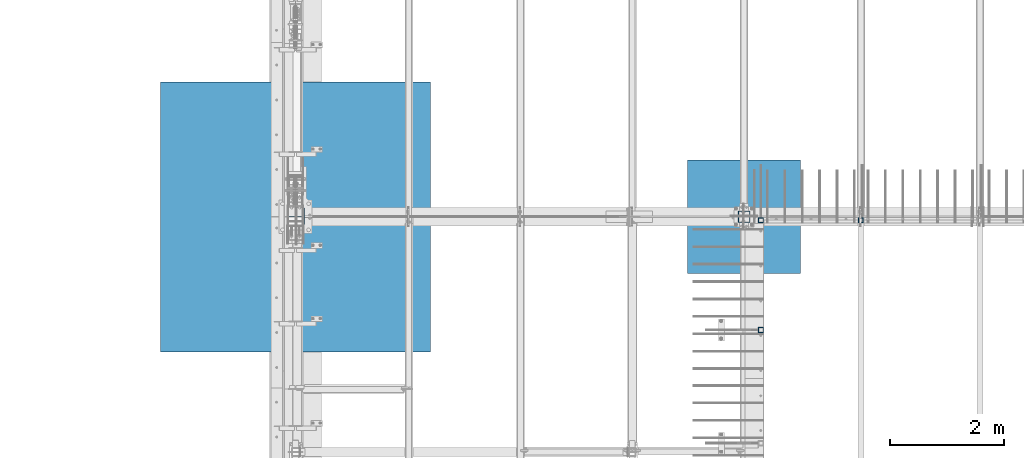
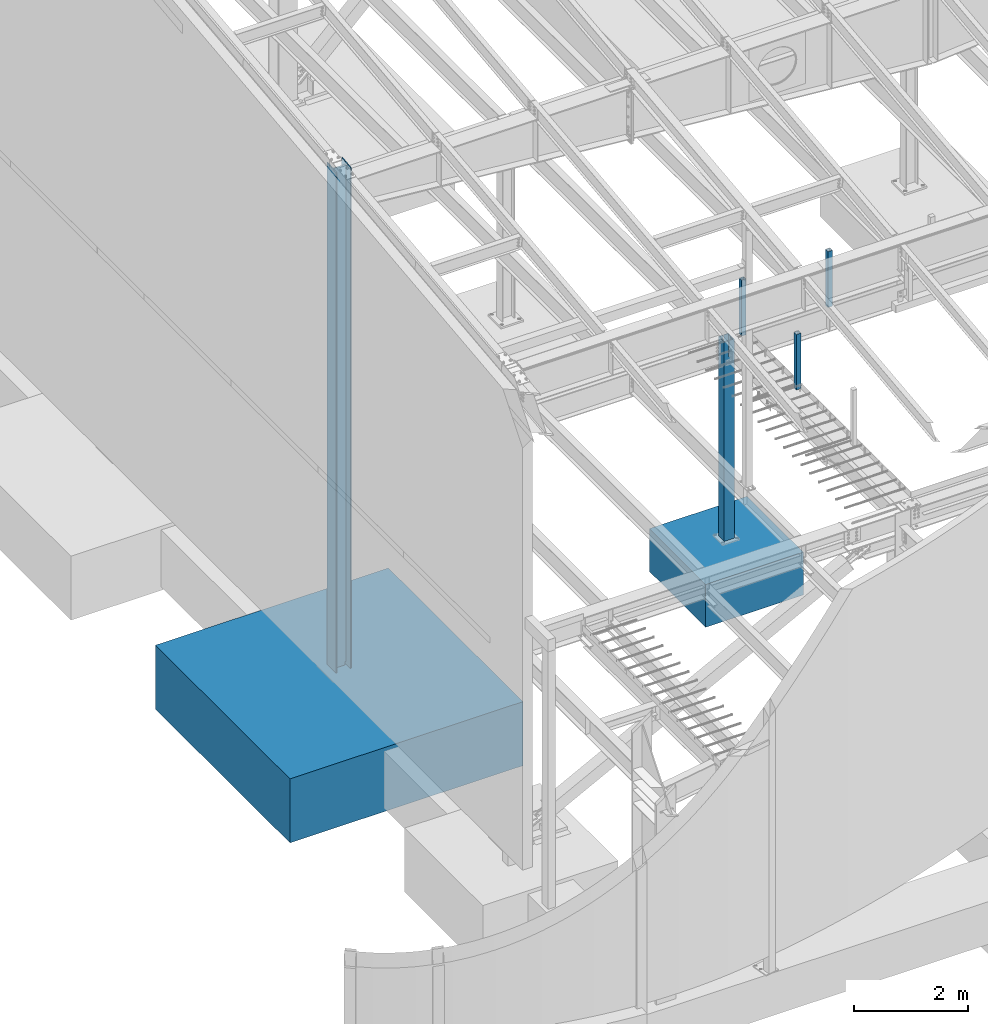
# One storey, part 352 of 1179: 7 columns, 7 elements without a shape of their own.
"""IFC2X3 building model written with IfcOpenShell, lengths in millimetres."""

from ifc_helpers import new_model, si_unit, frame, origin_with_axes, place, context, subcontext, project, spatial, faceted_brep, material, type_object, element, aggregate, save


model = new_model("IFC2X3")

# Units and contexts
model_context = context("Model", 3, precision=1e-05, world=origin_with_axes())
body_context = subcontext(model_context, "Body", "Model", "MODEL_VIEW")
ifc_project = project(units=[si_unit("LENGTHUNIT", "METRE", prefix="MILLI"), si_unit("AREAUNIT", "SQUARE_METRE"), si_unit("VOLUMEUNIT", "CUBIC_METRE"), si_unit("MASSUNIT", "GRAM", prefix="KILO"), si_unit("TIMEUNIT", "SECOND"), si_unit("PLANEANGLEUNIT", "RADIAN"), si_unit("SOLIDANGLEUNIT", "STERADIAN"), si_unit("THERMODYNAMICTEMPERATUREUNIT", "DEGREE_CELSIUS"), si_unit("LUMINOUSINTENSITYUNIT", "LUMEN")], contexts=[model_context])

# Site, building, storey
site_placement = place(None, origin_with_axes())
site = spatial("IfcSite", under=ifc_project, at=site_placement, CompositionType="ELEMENT")
building_placement = place(site_placement, origin_with_axes())
building = spatial("IfcBuilding", under=site, at=building_placement, Name="Undefined", CompositionType="ELEMENT")
storey_placement = place(building_placement, origin_with_axes())
storey = spatial("IfcBuildingStorey", under=building, at=storey_placement, Name="Undefined", CompositionType="ELEMENT", Elevation=0.0)

# Assembly, column
assembly_1_placement = place(storey_placement, origin_with_axes())
assembly_1 = element("IfcElementAssembly", 1, at=assembly_1_placement, inside=storey, Name="COLUMN", AssemblyPlace="NOTDEFINED", PredefinedType="RIGID_FRAME")
ifc_material_1 = material()
column_type_1 = type_object("IfcColumnType", Name="HSS3-1/2X3-1/2X5/16", PredefinedType="NOTDEFINED")
column_1_placement = place(assembly_1_placement, frame((10325.1, 11420.475, 4102.1), z_axis=(0.0, 1.0, 0.0), x_axis=(0.0, 0.0, 1.0)))
column_1 = element("IfcColumn", 2, at=column_1_placement, type_object=column_type_1, material=ifc_material_1, Name="COLUMN", ObjectType="HSS3-1/2X3-1/2X5/16", context=body_context, shape_type="Brep", body=[
    faceted_brep([(0.0, 36.5125000000007, -36.5125000000007), (0.0, -36.5125000000007, -36.5125000000007), (1195.387, -36.5125000000007, -36.5125000000007), (1195.387, 36.5125000000007, -36.5125000000007), (0.0, -36.5125000000007, 36.5125000000007), (1195.387, -36.5125000000007, 36.5125000000007), (0.0, 36.5125000000007, 36.5125000000007), (1195.387, 36.5125000000007, 36.5125000000007), (0.0, 44.4500000000007, -44.4499999999998), (0.0, 44.4500000000007, 44.4500000000007), (1195.387, 44.4500000000007, 44.4500000000007), (1195.387, 44.4500000000007, -44.4500000000007), (0.0, -44.4500000000007, 44.4500000000007), (1195.387, -44.4500000000007, 44.4500000000007), (0.0, -44.4500000000007, -44.4500000000007), (1195.387, -44.4500000000007, -44.4500000000007)], [[[0, 1, 2, 3]], [[1, 4, 5, 2]], [[4, 6, 7, 5]], [[6, 0, 3, 7]], [[8, 9, 10, 11]], [[9, 12, 13, 10]], [[12, 14, 15, 13]], [[14, 8, 11, 15]], [[13, 15, 11, 10], [5, 7, 3, 2]], [[14, 12, 9, 8], [6, 4, 1, 0]]]),
])
aggregate(assembly_1, [column_1])

assembly_2_placement = place(storey_placement, origin_with_axes())
assembly_2 = element("IfcElementAssembly", 3, at=assembly_2_placement, inside=storey, Name="COLUMN", AssemblyPlace="NOTDEFINED", PredefinedType="RIGID_FRAME")
column_2_placement = place(assembly_2_placement, frame((8575.675, 9499.6, 4108.45), z_axis=(0.0, 1.0, 0.0), x_axis=(0.0, 0.0, 1.0)))
column_2 = element("IfcColumn", 4, at=column_2_placement, type_object=column_type_1, material=ifc_material_1, Name="COLUMN", ObjectType="HSS3-1/2X3-1/2X5/16", context=body_context, shape_type="Brep", body=[
    faceted_brep([(0.0, 36.5125000000007, -36.5125000000007), (0.0, -36.5125000000007, -36.5125000000007), (1189.03749999998, -36.5125000000007, -36.5124999999998), (1189.03749999998, 36.5125000000007, -36.5124999999998), (0.0, -36.5125000000007, 36.5125000000007), (1189.03749999998, -36.5125000000007, 36.5124999999998), (0.0, 36.5125000000007, 36.5125000000007), (1189.03749999998, 36.5125000000007, 36.5124999999998), (0.0, 44.4500000000007, -44.4499999999998), (0.0, 44.4500000000007, 44.4500000000007), (1189.03749999998, 44.4500000000007, 44.4499999999998), (1189.03749999998, 44.4500000000007, -44.4499999999998), (0.0, -44.4500000000007, 44.4500000000007), (1189.03749999998, -44.4500000000007, 44.4499999999998), (0.0, -44.4500000000007, -44.4500000000007), (1189.03749999998, -44.4500000000007, -44.4499999999998)], [[[0, 1, 2, 3]], [[1, 4, 5, 2]], [[4, 6, 7, 5]], [[6, 0, 3, 7]], [[8, 9, 10, 11]], [[9, 12, 13, 10]], [[12, 14, 15, 13]], [[14, 8, 11, 15]], [[13, 15, 11, 10], [5, 7, 3, 2]], [[14, 12, 9, 8], [6, 4, 1, 0]]]),
])
aggregate(assembly_2, [column_2])

assembly_3_placement = place(storey_placement, origin_with_axes())
assembly_3 = element("IfcElementAssembly", 5, at=assembly_3_placement, inside=storey, Name="COLUMN", AssemblyPlace="NOTDEFINED", PredefinedType="RIGID_FRAME")
column_3_placement = place(assembly_3_placement, frame((8575.675, 11420.475, 4102.1), z_axis=(0.0, 1.0, 0.0), x_axis=(0.0, 0.0, 1.0)))
column_3 = element("IfcColumn", 6, at=column_3_placement, type_object=column_type_1, material=ifc_material_1, Name="COLUMN", ObjectType="HSS3-1/2X3-1/2X5/16", context=body_context, shape_type="Brep", body=[
    faceted_brep([(0.0, 36.5125000000007, -36.5125000000007), (0.0, -36.5125000000007, -36.5125000000007), (1195.387, -36.5125000000007, -36.5125000000007), (1195.387, 36.5125000000007, -36.5125000000007), (0.0, -36.5125000000007, 36.5125000000007), (1195.387, -36.5125000000007, 36.5125000000007), (0.0, 36.5125000000007, 36.5125000000007), (1195.387, 36.5125000000007, 36.5125000000007), (0.0, 44.4500000000007, -44.4499999999998), (0.0, 44.4500000000007, 44.4500000000007), (1195.387, 44.4500000000007, 44.4500000000007), (1195.387, 44.4500000000007, -44.4500000000007), (0.0, -44.4500000000007, 44.4500000000007), (1195.387, -44.4500000000007, 44.4500000000007), (0.0, -44.4500000000007, -44.4500000000007), (1195.387, -44.4500000000007, -44.4500000000007)], [[[0, 1, 2, 3]], [[1, 4, 5, 2]], [[4, 6, 7, 5]], [[6, 0, 3, 7]], [[8, 9, 10, 11]], [[9, 12, 13, 10]], [[12, 14, 15, 13]], [[14, 8, 11, 15]], [[13, 15, 11, 10], [5, 7, 3, 2]], [[14, 12, 9, 8], [6, 4, 1, 0]]]),
])
aggregate(assembly_3, [column_3])

assembly_4_placement = place(storey_placement, origin_with_axes())
assembly_4 = element("IfcElementAssembly", 7, at=assembly_4_placement, inside=storey, Name="FOOTING", AssemblyPlace="NOTDEFINED", PredefinedType="REINFORCEMENT_UNIT")
ifc_material_2 = material(Name="CONCRETE/3000")
column_type_2 = type_object("IfcColumnType", PredefinedType="NOTDEFINED")
column_4_placement = place(assembly_4_placement, frame((431.800000000002, 11480.8, -1727.2), z_axis=(-1.0, 0.0, 0.0), x_axis=(0.0, 0.0, 1.0)))
column_4 = element("IfcColumn", 8, at=column_4_placement, type_object=column_type_2, material=ifc_material_2, Name="FOOTING", context=body_context, shape_type="Brep", body=[
    faceted_brep([(0.0, 2362.2, -2362.2), (0.0, 2362.2, 2362.2), (1371.6, 2362.2, 2362.2), (1371.6, 2362.2, -2362.2), (0.0, -2362.2, 2362.2), (1371.6, -2362.2, 2362.2), (0.0, -2362.2, -2362.2), (1371.6, -2362.2, -2362.2)], [[[0, 1, 2, 3]], [[1, 4, 5, 2]], [[4, 6, 7, 5]], [[6, 0, 3, 7]], [[5, 7, 3, 2]], [[6, 4, 1, 0]]]),
])
aggregate(assembly_4, [column_4])

assembly_5_placement = place(storey_placement, origin_with_axes())
assembly_5 = element("IfcElementAssembly", 9, at=assembly_5_placement, inside=storey, Name="FOOTING", AssemblyPlace="NOTDEFINED", PredefinedType="REINFORCEMENT_UNIT")
column_type_3 = type_object("IfcColumnType", PredefinedType="NOTDEFINED")
column_5_placement = place(assembly_5_placement, frame((8280.4, 11480.8, -1168.4), z_axis=(-1.0, 0.0, 0.0), x_axis=(0.0, 0.0, 1.0)))
column_5 = element("IfcColumn", 10, at=column_5_placement, type_object=column_type_3, material=ifc_material_2, Name="FOOTING", context=body_context, shape_type="Brep", body=[
    faceted_brep([(0.0, 990.6, -990.599999999999), (0.0, 990.6, 990.6), (914.4, 990.6, 990.6), (914.4, 990.6, -990.599999999999), (0.0, -990.6, 990.6), (914.4, -990.6, 990.6), (0.0, -990.6, -990.599999999999), (914.4, -990.6, -990.599999999999)], [[[0, 1, 2, 3]], [[1, 4, 5, 2]], [[4, 6, 7, 5]], [[6, 0, 3, 7]], [[5, 7, 3, 2]], [[6, 4, 1, 0]]]),
])
aggregate(assembly_5, [column_5])

assembly_6_placement = place(storey_placement, origin_with_axes())
assembly_6 = element("IfcElementAssembly", 11, at=assembly_6_placement, inside=storey, Name="COLUMN", AssemblyPlace="NOTDEFINED", PredefinedType="RIGID_FRAME")
ifc_material_3 = material(Name="STEEL/A992")
column_type_4 = type_object("IfcColumnType", Name="W12X79", PredefinedType="NOTDEFINED")
column_6_placement = place(assembly_6_placement, frame((431.800000000002, 11480.8, -355.6), z_axis=(-1.0, 0.0, 0.0), x_axis=(0.0, 0.0, 1.0)))
column_6 = element("IfcColumn", 12, at=column_6_placement, type_object=column_type_4, material=ifc_material_3, Name="COLUMN", ObjectType="W12X79", context=body_context, shape_type="Brep", body=[
    faceted_brep([(160.223581529497, -153.987499999999, 157.1625), (160.223581529497, 153.987499999999, 157.1625), (149.225002356772, 153.987499999999, 138.1125), (149.225002356772, 6.35000012494493, 138.1125), (148.995793121516, 6.35000012313685, 137.715499999996), (148.995793121516, -6.34999999999854, 137.715499999996), (149.225002356772, -6.34999999999854, 138.1125), (149.225002356772, -153.987499999999, 138.1125), (188.913, -6.34999999999854, 137.715499999996), (188.913, 6.35000008947463, 137.715499999996), (208.49066058208, 6.35000008789211, 131.2871410688), (208.49066058208, -6.34999999999854, 131.2871410688), (212.873373738864, 6.35000008718271, 128.290736246858), (212.873373738864, -6.34999999999854, 128.290736246858), (214.971292158606, 6.35000008606585, 123.413713099926), (214.971292158606, -6.34999999999854, 123.413713099926), (214.132634973196, 6.3500000848835, 118.171264187733), (214.132634973196, -6.34999999999854, 118.171264187733), (210.617956026487, 6.35000008400311, 114.192112472459), (210.617956026487, -6.34999999999854, 114.192112472459), (205.519195059062, 6.35000008370116, 112.712499999996), (205.519195059062, -6.34999999999854, 112.712499999996), (139.700000000001, 6.34999999999854, 112.7125), (147.032309983244, -6.35000007376584, 112.7125), (139.700000000001, 6.34999999999854, -112.7125), (147.032309983244, -6.35000000747095, -112.7125), (205.519195059063, 6.3500000365857, -112.712500000003), (205.519195059063, -6.34999999999854, -112.712500000003), (210.617956026486, 6.35000003621826, -114.192112472468), (210.617956026486, -6.34999999999854, -114.192112472468), (214.132634973195, 6.35000003529422, -118.171264187741), (214.132634973195, -6.34999999999854, -118.171264187741), (214.971292158605, 6.35000003410096, -123.413713099934), (214.971292158605, -6.34999999999854, -123.413713099934), (212.873373738863, 6.35000003300956, -128.290736246865), (212.873373738863, -6.34999999999854, -128.290736246865), (208.49066058208, 6.35000003235837, -131.287141068808), (208.49066058208, -6.34999999999854, -131.287141068808), (188.913, 6.35000003102323, -137.715500000003), (188.913, -6.34999999999854, -137.715500000003), (148.99620123074, 6.35000000162472, -137.715500000003), (148.99620123074, -6.34999999999854, -137.715500000003), (10871.8469167151, 6.35000000000036, -138.1125), (10900.5223513917, 6.35000000000036, -138.1125), (10917.2051931417, 153.987499999999, -138.1125), (149.225402461476, 153.987499999999, -138.1125), (149.225402461477, 6.34999999999854, -138.1125), (10882.4044264804, -153.987499999999, -138.1125), (10882.4044264804, -153.987499999999, -157.1625), (10917.2051931417, 153.987499999999, -157.1625), (10899.0872682304, -6.35000000000036, -138.1125), (149.225402461476, -153.987499999999, -138.1125), (160.223597538519, -153.987499999999, -157.1625), (160.223597538519, 153.987499999999, -157.1625), (149.225402461476, -6.34999999999854, -138.1125), (10870.4118335538, -6.35000000000036, -138.1125), (10871.8469167151, 6.35000000000036, 138.1125), (10870.4118335538, -6.35000000021682, 138.1125), (10900.5219999928, 6.35000000038963, 138.112500000628), (10899.0872682304, -6.35000000000036, 138.1125), (10917.2051931417, 153.987499999999, 138.1125), (10917.2051931417, 153.987499999999, 157.1625), (10882.4044264804, -153.987499999999, 157.1625), (10882.4044264804, -153.987499999999, 138.1125)], [[[0, 1, 2, 3, 4, 5, 6, 7]], [[8, 9, 10, 11]], [[11, 10, 12, 13]], [[13, 12, 14, 15]], [[15, 14, 16, 17]], [[17, 16, 18, 19]], [[19, 18, 20, 21]], [[21, 20, 22, 23]], [[24, 25, 23, 22]], [[25, 24, 26, 27]], [[27, 26, 28, 29]], [[29, 28, 30, 31]], [[31, 30, 32, 33]], [[33, 32, 34, 35]], [[35, 34, 36, 37]], [[37, 36, 38, 39]], [[39, 38, 40, 41]], [[42, 43, 44, 45, 46]], [[47, 48, 49, 44, 43, 50]], [[48, 47, 51, 52]], [[49, 48, 52, 53]], [[44, 49, 53, 45]], [[52, 51, 54, 41, 40, 46, 45, 53]], [[47, 50, 55, 54, 51]], [[43, 42, 55, 50]], [[56, 57, 55, 42]], [[58, 59, 57, 56]], [[60, 61, 62, 63, 59, 58]], [[63, 62, 0, 7]], [[57, 59, 63, 7, 6]], [[8, 11, 13, 15, 17, 19, 21, 23, 25, 27, 29, 31, 33, 35, 37, 39, 41, 54, 55, 57, 6, 5]], [[9, 8, 5, 4]], [[56, 42, 46, 40, 38, 36, 34, 32, 30, 28, 26, 24, 22, 20, 18, 16, 14, 12, 10, 9, 4, 3]], [[60, 58, 56, 3, 2]], [[61, 60, 2, 1]], [[62, 61, 1, 0]]]),
])
aggregate(assembly_6, [column_6])

assembly_7_placement = place(storey_placement, origin_with_axes())
assembly_7 = element("IfcElementAssembly", 13, at=assembly_7_placement, inside=storey, Name="COLUMN", AssemblyPlace="NOTDEFINED", PredefinedType="RIGID_FRAME")
column_type_5 = type_object("IfcColumnType", Name="HSS8X8X3/8", PredefinedType="NOTDEFINED")
column_7_placement = place(assembly_7_placement, frame((8280.4, 11480.8, -355.6), z_axis=(0.0, 1.0, 0.0), x_axis=(0.0, 0.0, 1.0)))
column_7 = element("IfcColumn", 14, at=column_7_placement, type_object=column_type_5, material=ifc_material_1, Name="COLUMN", ObjectType="HSS8X8X3/8", context=body_context, shape_type="Brep", body=[
    faceted_brep([(4451.35, -1.58750000000509, 101.6), (4116.38749990463, -1.58750000000509, 101.6), (4116.38749990463, -1.58750000000509, 92.0750000000007), (4451.35, -1.58750000000509, 92.0750000000007), (4113.95746014561, -2.07086496130069, 101.6), (4113.95746014561, -2.07086496130069, 92.0750000000007), (4111.89737191153, -3.44737191153763, 101.6), (4111.89737191153, -3.44737191153763, 92.0750000000007), (4110.5208649613, -5.50746014561446, 101.6), (4110.5208649613, -5.50746014561446, 92.0750000000007), (4110.0375, -7.93750009536961, 101.6), (4110.0375, -7.93750009536961, 92.0750000000007), (4110.5208649613, -10.3675398543928, 101.6), (4110.5208649613, -10.3675398543928, 92.0750000000007), (4111.89737191153, -12.4276280884696, 101.6), (4111.89737191153, -12.4276280884696, 92.0750000000007), (4113.95746014561, -13.8041350387066, 101.6), (4113.95746014561, -13.8041350387066, 92.0750000000007), (4116.38749990463, -14.2875000000022, 101.6), (4116.38749990463, -14.2875000000022, 92.0750000000007), (4451.35000009537, -14.2875000000022, 101.6), (4451.35, -14.2875000000022, 92.0750000000007), (4037.75746014561, -101.6, 15.391635038708), (4037.75746014561, -92.0750000000007, 15.391635038708), (4040.18749990463, -92.0750000000007, 15.8750000000018), (4040.18749990463, -101.6, 15.8750000000018), (4035.69737191153, -101.6, 14.0151280884693), (4035.69737191153, -92.0750000000007, 14.0151280884693), (4034.32086496129, -101.6, 11.9550398543925), (4034.32086496129, -92.0750000000007, 11.9550398543925), (4033.8375, -101.6, 9.52500009536925), (4033.8375, -92.0750000000007, 9.52500009536925), (4034.32086496129, -101.6, 7.09496014561046), (4034.32086496129, -92.0750000000007, 7.09496014561046), (4035.69737191153, -101.6, 5.03487191153363), (4035.69737191153, -92.0750000000007, 5.03487191153363), (4037.75746014561, -101.6, 3.65836496129486), (4037.75746014561, -92.0750000000007, 3.65836496129486), (4040.18749990463, -101.6, 3.17500000000109), (4040.18749990463, -92.0750000000007, 3.17500000000109), (4451.35, -101.6, 3.17500000000109), (4451.35, -92.0750000000007, 3.17500000000109), (4451.35, -92.0750000000007, -92.0750000000007), (4451.35, -101.6, -101.6), (4451.35, -14.2875000000022, -101.6), (4451.35000009537, -14.2875000000022, -92.0750000000007), (4037.75746014561, 92.0750000000007, 15.391635038708), (4037.75746014561, 101.599999999999, 15.391635038708), (4040.18749990463, 101.599999999999, 15.8750000000018), (4040.18749990463, 92.0750000000007, 15.8750000000018), (4035.69737191153, 92.0750000000007, 14.0151280884693), (4035.69737191153, 101.599999999999, 14.0151280884693), (4034.32086496129, 92.0750000000007, 11.9550398543925), (4034.32086496129, 101.599999999999, 11.9550398543925), (4033.8375, 92.0750000000007, 9.52500009536925), (4033.8375, 101.599999999999, 9.52500009536925), (4034.32086496129, 92.0750000000007, 7.09496014561046), (4034.32086496129, 101.599999999999, 7.09496014561046), (4035.69737191153, 92.0750000000007, 5.03487191153363), (4035.69737191153, 101.599999999999, 5.03487191153363), (4037.75746014561, 92.0750000000007, 3.65836496129486), (4037.75746014561, 101.599999999999, 3.65836496129486), (4040.18749990463, 92.0750000000007, 3.17500000000109), (4040.18749990463, 101.599999999999, 3.17500000000109), (4451.35, 92.0750000000007, 3.17500000000109), (4451.35, 101.599999999999, 3.17500000000109), (4451.35, 101.599999999999, -101.6), (177.8, 101.599999999999, -101.6), (177.8, 101.599999999999, 101.6), (4451.35, 101.599999999999, 101.6), (4451.35, 101.599999999999, 15.8750000000018), (4451.35000009537, 92.0750000000007, 15.8750000000018), (4451.35, 92.0750000000007, 92.0750000000007), (177.8, 92.0750000000007, 92.0750000000007), (177.8, 92.0750000000007, -92.0750000000007), (4451.35, 92.0750000000007, -92.0750000000007), (4451.35, -1.58750000000509, -92.0750000000007), (4451.35, -1.58750000000509, -101.6), (177.8, -101.6, -101.6), (4116.38749990463, -1.58750000000509, -101.6), (4113.95746014561, -2.07086496130069, -101.6), (4111.89737191153, -3.44737191153763, -101.6), (4110.5208649613, -5.50746014561446, -101.6), (4110.0375, -7.93749990463766, -101.6), (4110.5208649613, -10.3675398543928, -101.6), (4111.89737191153, -12.4276280884696, -101.6), (4113.95746014561, -13.8041350387066, -101.6), (4116.38749990463, -14.2875000000022, -101.6), (4116.38749990463, -1.58750000000509, -92.0750000000007), (4113.95746014561, -2.07086496130069, -92.0750000000007), (4111.89737191153, -3.44737191153763, -92.0750000000007), (4110.5208649613, -5.50746014561446, -92.0750000000007), (4110.0375, -7.93749990463766, -92.0750000000007), (4110.5208649613, -10.3675398543928, -92.0750000000007), (4111.89737191153, -12.4276280884696, -92.0750000000007), (4113.95746014561, -13.8041350387066, -92.0750000000007), (4116.38749990463, -14.2875000000022, -92.0750000000007), (177.8, -92.0750000000007, -92.0750000000007), (177.8, -101.6, 101.6), (177.8, -92.0750000000007, 92.0750000000007), (4451.35, -92.0750000000007, 92.0750000000007), (4451.35, -92.0750000000007, 15.8750000000018), (4451.35000009537, -101.6, 15.8750000000018), (4451.35, -101.6, 101.6)], [[[0, 1, 2, 3]], [[4, 5, 2, 1]], [[6, 7, 5, 4]], [[8, 9, 7, 6]], [[10, 11, 9, 8]], [[12, 13, 11, 10]], [[14, 15, 13, 12]], [[16, 17, 15, 14]], [[18, 19, 17, 16]], [[20, 21, 19, 18]], [[22, 23, 24, 25]], [[26, 27, 23, 22]], [[28, 29, 27, 26]], [[30, 31, 29, 28]], [[32, 33, 31, 30]], [[34, 35, 33, 32]], [[36, 37, 35, 34]], [[38, 39, 37, 36]], [[40, 41, 39, 38]], [[42, 41, 40, 43, 44, 45]], [[46, 47, 48, 49]], [[50, 51, 47, 46]], [[52, 53, 51, 50]], [[54, 55, 53, 52]], [[56, 57, 55, 54]], [[58, 59, 57, 56]], [[60, 61, 59, 58]], [[62, 63, 61, 60]], [[64, 65, 63, 62]], [[47, 51, 53, 55, 57, 59, 61, 63, 65, 66, 67, 68, 69, 70, 48]], [[71, 49, 48, 70]], [[72, 73, 74, 75, 64, 62, 60, 58, 56, 54, 52, 50, 46, 49, 71]], [[66, 65, 64, 75, 76, 77]], [[43, 78, 67, 66, 77, 79, 80, 81, 82, 83, 84, 85, 86, 87, 44]], [[76, 88, 79, 77]], [[89, 80, 79, 88]], [[90, 81, 80, 89]], [[91, 82, 81, 90]], [[92, 83, 82, 91]], [[93, 84, 83, 92]], [[94, 85, 84, 93]], [[95, 86, 85, 94]], [[96, 87, 86, 95]], [[45, 44, 87, 96]], [[95, 94, 93, 92, 91, 90, 89, 88, 76, 75, 74, 97, 42, 45, 96]], [[78, 98, 68, 67], [73, 99, 97, 74]], [[23, 27, 29, 31, 33, 35, 37, 39, 41, 42, 97, 99, 100, 101, 24]], [[102, 25, 24, 101]], [[103, 98, 78, 43, 40, 38, 36, 34, 32, 30, 28, 26, 22, 25, 102]], [[16, 14, 12, 10, 8, 6, 4, 1, 0, 69, 68, 98, 103, 20, 18]], [[72, 71, 70, 69, 0, 3]], [[100, 99, 73, 72, 3, 2, 5, 7, 9, 11, 13, 15, 17, 19, 21]], [[103, 102, 101, 100, 21, 20]]]),
])
aggregate(assembly_7, [column_7])

save(model, "model.ifc")
